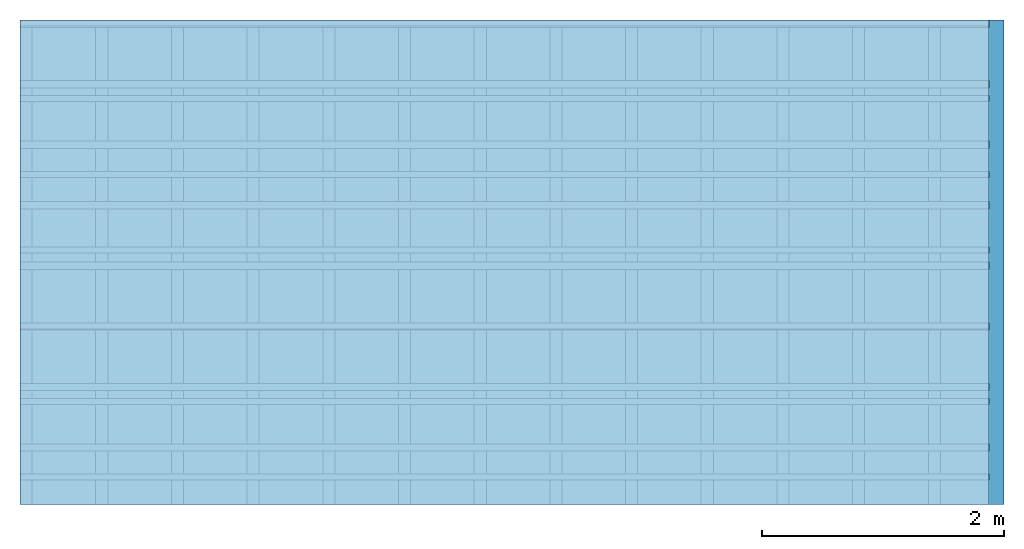
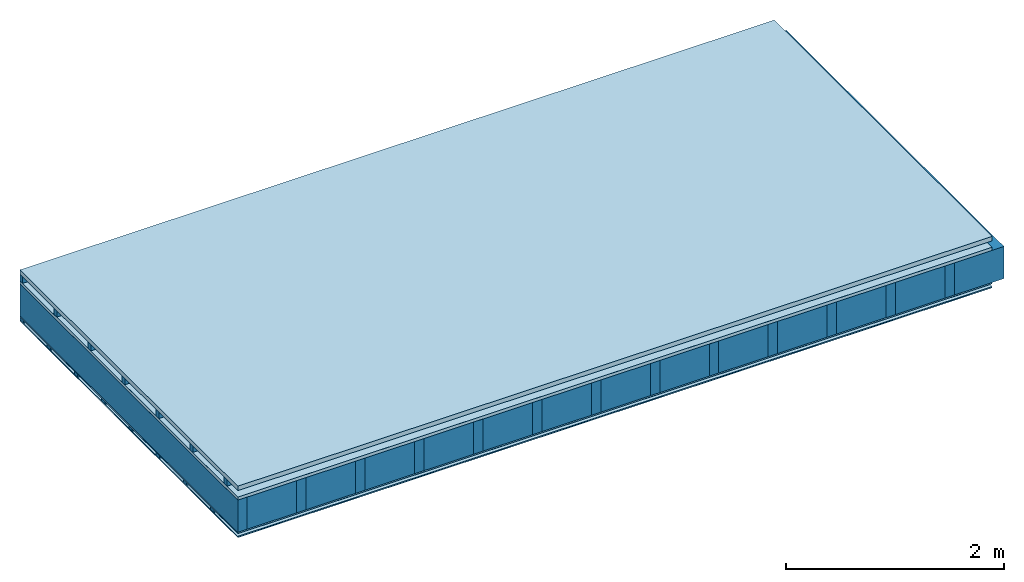
# One storey: 7 plates, 4 members, 1 element without a shape of its own.
"""IFC4 building model written with IfcOpenShell, lengths in metres."""

from ifc_helpers import new_model, si_unit, derived_unit, direction, frame, frame_2d, origin, origin_with_axes, place, context, project, spatial, rectangle, extrude, material, layer, layer_set, type_object, element, aggregate, save


model = new_model("IFC4")

# Units and contexts
plan_context = context("Plan", 3, precision=1e-05, world=origin(), true_north=direction((0.0, 1.0)))
model_context = context("Model", 3, precision=1e-05, world=origin(), true_north=direction((0.0, 1.0)))
ifc_project = project(units=[si_unit("LENGTHUNIT", "METRE"), derived_unit("SOUNDPRESSUREUNIT", [(si_unit("PRESSUREUNIT", "PASCAL", prefix="MICRO"), 0)]), si_unit("ENERGYUNIT", "JOULE", prefix="MEGA"), si_unit("MASSUNIT", "GRAM", prefix="KILO"), derived_unit("THERMALTRANSMITTANCEUNIT", [(si_unit("POWERUNIT", "WATT"), 1), (si_unit("AREAUNIT", "SQUARE_METRE"), -1), (si_unit("THERMODYNAMICTEMPERATUREUNIT", "KELVIN"), -1)]), derived_unit("AREADENSITYUNIT", [(si_unit("MASSUNIT", "GRAM", prefix="KILO"), 1), (si_unit("AREAUNIT", "SQUARE_METRE"), -1)]), derived_unit("USERDEFINED", [(si_unit("ENERGYUNIT", "JOULE", prefix="MEGA"), 1), (si_unit("AREAUNIT", "SQUARE_METRE"), -1)])], contexts=[plan_context, model_context])

# Site, building, storey
site = spatial("IfcSite", under=ifc_project)
building_placement = place(None, origin())
building = spatial("IfcBuilding", under=site, at=building_placement)
storey_placement = place(building_placement, origin())
storey = spatial("IfcBuildingStorey", under=building, at=storey_placement)

# Slab, members, plates
ifc_material_1 = material(Name="Roof tiles", Category="03.015")
ifc_layer_1 = layer(ifc_material_1, 0.05, Name="Roofing")
ifc_layer_2 = layer(None, 0.072, Name="Battens / profiles")
ifc_material_2 = material(Name="Roofing underlay", Category="09.008")
ifc_layer_3 = layer(ifc_material_2, 0.00018, Name="Under the roof")
ifc_material_3 = material(Category="10.009")
ifc_layer_4 = layer(ifc_material_3, 0.035, Name="Sub-floor")
ifc_material_4 = material(Name="of the art")
ifc_layer_5 = layer(ifc_material_4, 0.0, Name="Bond")
ifc_layer_6 = layer(None, 0.36, Name="Supporting structure")
ifc_material_5 = material(Name="OSB3 panel", Category="07.013")
ifc_layer_7 = layer(ifc_material_5, 0.015, Name="Lower layer 1")
ifc_material_6 = material(Name="Vapor barrier polyethylene (PE)", Category="09.002")
ifc_layer_8 = layer(ifc_material_6, 0.00025, Name="Vapor barrier")
ifc_layer_9 = layer(None, 0.03, Name="Battens / profiles")
ifc_material_7 = material(Name="Plasterboard type A", Category="03.008")
ifc_layer_10 = layer(ifc_material_7, 0.0125, Name="Covering below 1st layer")
ifc_material_8 = material(Category="04.001")
ifc_layer_11 = layer(ifc_material_8, 0.003, Name="Surface below")
ifc_layer_set = layer_set([ifc_layer_1, ifc_layer_2, ifc_layer_3, ifc_layer_4, ifc_layer_5, ifc_layer_6, ifc_layer_7, ifc_layer_8, ifc_layer_9, ifc_layer_10, ifc_layer_11])
slab_type = type_object("IfcSlabType", Name="E0180", PredefinedType="NOTDEFINED", material=ifc_layer_set)
slab_placement = place(None, frame((0.0, 0.0, 0.0), z_axis=(0.0, 0.0, -1.0), x_axis=(1.0, 0.0, 0.0)))
slab = element("IfcSlab", 1, at=slab_placement, inside=storey, type_object=slab_type, material=ifc_layer_set, Name="Slab #1")
ifc_material_9 = material()
member_1_placement = place(slab_placement, origin())
member_1 = element("IfcMember", 2, at=member_1_placement, material=ifc_material_9, Name="Battens / profiles", context=plan_context, shape_type="SweptSolid", body=[
    extrude(rectangle(XDim=0.05, YDim=0.072, at=frame_2d((0.025, 0.036), x_axis=(1.0, 0.0))), frame((0.0, 0.0, 0.05), z_axis=(1.0, 0.0, 0.0), x_axis=(0.0, 1.0, 0.0)), (0.0, 0.0, 1.0), 8.0),
    extrude(rectangle(XDim=0.05, YDim=0.072, at=frame_2d((0.025, 0.036), x_axis=(1.0, 0.0))), frame((0.0, 0.625, 0.05), z_axis=(1.0, 0.0, 0.0), x_axis=(0.0, 1.0, 0.0)), (0.0, 0.0, 1.0), 8.0),
    extrude(rectangle(XDim=0.05, YDim=0.072, at=frame_2d((0.025, 0.036), x_axis=(1.0, 0.0))), frame((0.0, 1.25, 0.05), z_axis=(1.0, 0.0, 0.0), x_axis=(0.0, 1.0, 0.0)), (0.0, 0.0, 1.0), 8.0),
    extrude(rectangle(XDim=0.05, YDim=0.072, at=frame_2d((0.025, 0.036), x_axis=(1.0, 0.0))), frame((0.0, 1.875, 0.05), z_axis=(1.0, 0.0, 0.0), x_axis=(0.0, 1.0, 0.0)), (0.0, 0.0, 1.0), 8.0),
    extrude(rectangle(XDim=0.05, YDim=0.072, at=frame_2d((0.025, 0.036), x_axis=(1.0, 0.0))), frame((0.0, 2.5, 0.05), z_axis=(1.0, 0.0, 0.0), x_axis=(0.0, 1.0, 0.0)), (0.0, 0.0, 1.0), 8.0),
    extrude(rectangle(XDim=0.05, YDim=0.072, at=frame_2d((0.025, 0.036), x_axis=(1.0, 0.0))), frame((0.0, 3.125, 0.05), z_axis=(1.0, 0.0, 0.0), x_axis=(0.0, 1.0, 0.0)), (0.0, 0.0, 1.0), 8.0),
    extrude(rectangle(XDim=0.05, YDim=0.072, at=frame_2d((0.025, 0.036), x_axis=(1.0, 0.0))), frame((0.0, 3.75, 0.05), z_axis=(1.0, 0.0, 0.0), x_axis=(0.0, 1.0, 0.0)), (0.0, 0.0, 1.0), 8.0),
])
ifc_material_10 = material()
member_2_placement = place(slab_placement, origin())
member_2 = element("IfcMember", 3, at=member_2_placement, material=ifc_material_10, Name="Supporting structure", context=plan_context, shape_type="SweptSolid", body=[
    extrude(rectangle(XDim=0.1, YDim=0.36, at=frame_2d((0.05, 0.18), x_axis=(1.0, 0.0))), frame((0.0, 4.0, 0.15718), z_axis=(0.0, -1.0, 0.0), x_axis=(1.0, 0.0, 0.0)), (0.0, 0.0, 1.0), 4.0),
    extrude(rectangle(XDim=0.1, YDim=0.36, at=frame_2d((0.05, 0.18), x_axis=(1.0, 0.0))), frame((0.625, 4.0, 0.15718), z_axis=(0.0, -1.0, 0.0), x_axis=(1.0, 0.0, 0.0)), (0.0, 0.0, 1.0), 4.0),
    extrude(rectangle(XDim=0.1, YDim=0.36, at=frame_2d((0.05, 0.18), x_axis=(1.0, 0.0))), frame((1.25, 4.0, 0.15718), z_axis=(0.0, -1.0, 0.0), x_axis=(1.0, 0.0, 0.0)), (0.0, 0.0, 1.0), 4.0),
    extrude(rectangle(XDim=0.1, YDim=0.36, at=frame_2d((0.05, 0.18), x_axis=(1.0, 0.0))), frame((1.875, 4.0, 0.15718), z_axis=(0.0, -1.0, 0.0), x_axis=(1.0, 0.0, 0.0)), (0.0, 0.0, 1.0), 4.0),
    extrude(rectangle(XDim=0.1, YDim=0.36, at=frame_2d((0.05, 0.18), x_axis=(1.0, 0.0))), frame((2.5, 4.0, 0.15718), z_axis=(0.0, -1.0, 0.0), x_axis=(1.0, 0.0, 0.0)), (0.0, 0.0, 1.0), 4.0),
    extrude(rectangle(XDim=0.1, YDim=0.36, at=frame_2d((0.05, 0.18), x_axis=(1.0, 0.0))), frame((3.125, 4.0, 0.15718), z_axis=(0.0, -1.0, 0.0), x_axis=(1.0, 0.0, 0.0)), (0.0, 0.0, 1.0), 4.0),
    extrude(rectangle(XDim=0.1, YDim=0.36, at=frame_2d((0.05, 0.18), x_axis=(1.0, 0.0))), frame((3.75, 4.0, 0.15718), z_axis=(0.0, -1.0, 0.0), x_axis=(1.0, 0.0, 0.0)), (0.0, 0.0, 1.0), 4.0),
    extrude(rectangle(XDim=0.1, YDim=0.36, at=frame_2d((0.05, 0.18), x_axis=(1.0, 0.0))), frame((4.375, 4.0, 0.15718), z_axis=(0.0, -1.0, 0.0), x_axis=(1.0, 0.0, 0.0)), (0.0, 0.0, 1.0), 4.0),
    extrude(rectangle(XDim=0.1, YDim=0.36, at=frame_2d((0.05, 0.18), x_axis=(1.0, 0.0))), frame((5.0, 4.0, 0.15718), z_axis=(0.0, -1.0, 0.0), x_axis=(1.0, 0.0, 0.0)), (0.0, 0.0, 1.0), 4.0),
    extrude(rectangle(XDim=0.1, YDim=0.36, at=frame_2d((0.05, 0.18), x_axis=(1.0, 0.0))), frame((5.625, 4.0, 0.15718), z_axis=(0.0, -1.0, 0.0), x_axis=(1.0, 0.0, 0.0)), (0.0, 0.0, 1.0), 4.0),
    extrude(rectangle(XDim=0.1, YDim=0.36, at=frame_2d((0.05, 0.18), x_axis=(1.0, 0.0))), frame((6.25, 4.0, 0.15718), z_axis=(0.0, -1.0, 0.0), x_axis=(1.0, 0.0, 0.0)), (0.0, 0.0, 1.0), 4.0),
    extrude(rectangle(XDim=0.1, YDim=0.36, at=frame_2d((0.05, 0.18), x_axis=(1.0, 0.0))), frame((6.875, 4.0, 0.15718), z_axis=(0.0, -1.0, 0.0), x_axis=(1.0, 0.0, 0.0)), (0.0, 0.0, 1.0), 4.0),
    extrude(rectangle(XDim=0.1, YDim=0.36, at=frame_2d((0.05, 0.18), x_axis=(1.0, 0.0))), frame((7.5, 4.0, 0.15718), z_axis=(0.0, -1.0, 0.0), x_axis=(1.0, 0.0, 0.0)), (0.0, 0.0, 1.0), 4.0),
])
ifc_material_11 = material()
member_3_placement = place(slab_placement, origin())
member_3 = element("IfcMember", 4, at=member_3_placement, material=ifc_material_11, Name="Cavity", context=plan_context, shape_type="SweptSolid", body=[
    extrude(rectangle(XDim=0.525, YDim=0.36, at=frame_2d((0.2625, 0.18), x_axis=(1.0, 0.0))), frame((0.1, 4.0, 0.15718), z_axis=(0.0, -1.0, 0.0), x_axis=(1.0, 0.0, 0.0)), (0.0, 0.0, 1.0), 4.0),
    extrude(rectangle(XDim=0.525, YDim=0.36, at=frame_2d((0.2625, 0.18), x_axis=(1.0, 0.0))), frame((0.725, 4.0, 0.15718), z_axis=(0.0, -1.0, 0.0), x_axis=(1.0, 0.0, 0.0)), (0.0, 0.0, 1.0), 4.0),
    extrude(rectangle(XDim=0.525, YDim=0.36, at=frame_2d((0.2625, 0.18), x_axis=(1.0, 0.0))), frame((1.35, 4.0, 0.15718), z_axis=(0.0, -1.0, 0.0), x_axis=(1.0, 0.0, 0.0)), (0.0, 0.0, 1.0), 4.0),
    extrude(rectangle(XDim=0.525, YDim=0.36, at=frame_2d((0.2625, 0.18), x_axis=(1.0, 0.0))), frame((1.975, 4.0, 0.15718), z_axis=(0.0, -1.0, 0.0), x_axis=(1.0, 0.0, 0.0)), (0.0, 0.0, 1.0), 4.0),
    extrude(rectangle(XDim=0.525, YDim=0.36, at=frame_2d((0.2625, 0.18), x_axis=(1.0, 0.0))), frame((2.6, 4.0, 0.15718), z_axis=(0.0, -1.0, 0.0), x_axis=(1.0, 0.0, 0.0)), (0.0, 0.0, 1.0), 4.0),
    extrude(rectangle(XDim=0.525, YDim=0.36, at=frame_2d((0.2625, 0.18), x_axis=(1.0, 0.0))), frame((3.225, 4.0, 0.15718), z_axis=(0.0, -1.0, 0.0), x_axis=(1.0, 0.0, 0.0)), (0.0, 0.0, 1.0), 4.0),
    extrude(rectangle(XDim=0.525, YDim=0.36, at=frame_2d((0.2625, 0.18), x_axis=(1.0, 0.0))), frame((3.85, 4.0, 0.15718), z_axis=(0.0, -1.0, 0.0), x_axis=(1.0, 0.0, 0.0)), (0.0, 0.0, 1.0), 4.0),
    extrude(rectangle(XDim=0.525, YDim=0.36, at=frame_2d((0.2625, 0.18), x_axis=(1.0, 0.0))), frame((4.475, 4.0, 0.15718), z_axis=(0.0, -1.0, 0.0), x_axis=(1.0, 0.0, 0.0)), (0.0, 0.0, 1.0), 4.0),
    extrude(rectangle(XDim=0.525, YDim=0.36, at=frame_2d((0.2625, 0.18), x_axis=(1.0, 0.0))), frame((5.1, 4.0, 0.15718), z_axis=(0.0, -1.0, 0.0), x_axis=(1.0, 0.0, 0.0)), (0.0, 0.0, 1.0), 4.0),
    extrude(rectangle(XDim=0.525, YDim=0.36, at=frame_2d((0.2625, 0.18), x_axis=(1.0, 0.0))), frame((5.725, 4.0, 0.15718), z_axis=(0.0, -1.0, 0.0), x_axis=(1.0, 0.0, 0.0)), (0.0, 0.0, 1.0), 4.0),
    extrude(rectangle(XDim=0.525, YDim=0.36, at=frame_2d((0.2625, 0.18), x_axis=(1.0, 0.0))), frame((6.35, 4.0, 0.15718), z_axis=(0.0, -1.0, 0.0), x_axis=(1.0, 0.0, 0.0)), (0.0, 0.0, 1.0), 4.0),
    extrude(rectangle(XDim=0.525, YDim=0.36, at=frame_2d((0.2625, 0.18), x_axis=(1.0, 0.0))), frame((6.975, 4.0, 0.15718), z_axis=(0.0, -1.0, 0.0), x_axis=(1.0, 0.0, 0.0)), (0.0, 0.0, 1.0), 4.0),
    extrude(rectangle(XDim=0.525, YDim=0.36, at=frame_2d((0.2625, 0.18), x_axis=(1.0, 0.0))), frame((7.6, 4.0, 0.15718), z_axis=(0.0, -1.0, 0.0), x_axis=(1.0, 0.0, 0.0)), (0.0, 0.0, 1.0), 4.0),
])
ifc_material_12 = material()
member_4_placement = place(slab_placement, origin())
member_4 = element("IfcMember", 5, at=member_4_placement, material=ifc_material_12, Name="Battens / profiles", context=plan_context, shape_type="SweptSolid", body=[
    extrude(rectangle(XDim=0.06, YDim=0.03, at=frame_2d((0.03, 0.015), x_axis=(1.0, 0.0))), frame((0.0, 0.0, 0.53243), z_axis=(1.0, 0.0, 0.0), x_axis=(0.0, 1.0, 0.0)), (0.0, 0.0, 1.0), 8.0),
    extrude(rectangle(XDim=0.06, YDim=0.03, at=frame_2d((0.03, 0.015), x_axis=(1.0, 0.0))), frame((0.0, 0.5, 0.53243), z_axis=(1.0, 0.0, 0.0), x_axis=(0.0, 1.0, 0.0)), (0.0, 0.0, 1.0), 8.0),
    extrude(rectangle(XDim=0.06, YDim=0.03, at=frame_2d((0.03, 0.015), x_axis=(1.0, 0.0))), frame((0.0, 1.0, 0.53243), z_axis=(1.0, 0.0, 0.0), x_axis=(0.0, 1.0, 0.0)), (0.0, 0.0, 1.0), 8.0),
    extrude(rectangle(XDim=0.06, YDim=0.03, at=frame_2d((0.03, 0.015), x_axis=(1.0, 0.0))), frame((0.0, 1.5, 0.53243), z_axis=(1.0, 0.0, 0.0), x_axis=(0.0, 1.0, 0.0)), (0.0, 0.0, 1.0), 8.0),
    extrude(rectangle(XDim=0.06, YDim=0.03, at=frame_2d((0.03, 0.015), x_axis=(1.0, 0.0))), frame((0.0, 2.0, 0.53243), z_axis=(1.0, 0.0, 0.0), x_axis=(0.0, 1.0, 0.0)), (0.0, 0.0, 1.0), 8.0),
    extrude(rectangle(XDim=0.06, YDim=0.03, at=frame_2d((0.03, 0.015), x_axis=(1.0, 0.0))), frame((0.0, 2.5, 0.53243), z_axis=(1.0, 0.0, 0.0), x_axis=(0.0, 1.0, 0.0)), (0.0, 0.0, 1.0), 8.0),
    extrude(rectangle(XDim=0.06, YDim=0.03, at=frame_2d((0.03, 0.015), x_axis=(1.0, 0.0))), frame((0.0, 3.0, 0.53243), z_axis=(1.0, 0.0, 0.0), x_axis=(0.0, 1.0, 0.0)), (0.0, 0.0, 1.0), 8.0),
    extrude(rectangle(XDim=0.06, YDim=0.03, at=frame_2d((0.03, 0.015), x_axis=(1.0, 0.0))), frame((0.0, 3.5, 0.53243), z_axis=(1.0, 0.0, 0.0), x_axis=(0.0, 1.0, 0.0)), (0.0, 0.0, 1.0), 8.0),
])
plate_1_placement = place(slab_placement, origin())
plate_1 = element("IfcPlate", 6, at=plate_1_placement, material=ifc_material_1, Name="Roofing", context=plan_context, shape_type="SweptSolid", body=[
    extrude(rectangle(XDim=8.0, YDim=4.0, at=frame_2d((4.0, 2.0), x_axis=(1.0, 0.0))), origin_with_axes(), (0.0, 0.0, 1.0), 0.05),
])
plate_2_placement = place(slab_placement, origin())
plate_2 = element("IfcPlate", 7, at=plate_2_placement, material=ifc_material_2, Name="Under the roof", context=plan_context, shape_type="SweptSolid", body=[
    extrude(rectangle(XDim=8.0, YDim=4.0, at=frame_2d((4.0, 2.0), x_axis=(1.0, 0.0))), frame((0.0, 0.0, 0.122), z_axis=(0.0, 0.0, 1.0), x_axis=(1.0, 0.0, 0.0)), (0.0, 0.0, 1.0), 0.00018),
])
plate_3_placement = place(slab_placement, origin())
plate_3 = element("IfcPlate", 8, at=plate_3_placement, material=ifc_material_3, Name="Sub-floor", context=plan_context, shape_type="SweptSolid", body=[
    extrude(rectangle(XDim=8.0, YDim=4.0, at=frame_2d((4.0, 2.0), x_axis=(1.0, 0.0))), frame((0.0, 0.0, 0.12218), z_axis=(0.0, 0.0, 1.0), x_axis=(1.0, 0.0, 0.0)), (0.0, 0.0, 1.0), 0.035),
])
plate_4_placement = place(slab_placement, origin())
plate_4 = element("IfcPlate", 9, at=plate_4_placement, material=ifc_material_5, Name="Lower layer 1", context=plan_context, shape_type="SweptSolid", body=[
    extrude(rectangle(XDim=8.0, YDim=4.0, at=frame_2d((4.0, 2.0), x_axis=(1.0, 0.0))), frame((0.0, 0.0, 0.51718), z_axis=(0.0, 0.0, 1.0), x_axis=(1.0, 0.0, 0.0)), (0.0, 0.0, 1.0), 0.015),
])
plate_5_placement = place(slab_placement, origin())
plate_5 = element("IfcPlate", 10, at=plate_5_placement, material=ifc_material_6, Name="Vapor barrier", context=plan_context, shape_type="SweptSolid", body=[
    extrude(rectangle(XDim=8.0, YDim=4.0, at=frame_2d((4.0, 2.0), x_axis=(1.0, 0.0))), frame((0.0, 0.0, 0.53218), z_axis=(0.0, 0.0, 1.0), x_axis=(1.0, 0.0, 0.0)), (0.0, 0.0, 1.0), 0.00025),
])
plate_6_placement = place(slab_placement, origin())
plate_6 = element("IfcPlate", 11, at=plate_6_placement, material=ifc_material_7, Name="Covering below 1st layer", context=plan_context, shape_type="SweptSolid", body=[
    extrude(rectangle(XDim=8.0, YDim=4.0, at=frame_2d((4.0, 2.0), x_axis=(1.0, 0.0))), frame((0.0, 0.0, 0.56243), z_axis=(0.0, 0.0, 1.0), x_axis=(1.0, 0.0, 0.0)), (0.0, 0.0, 1.0), 0.0125),
])
plate_7_placement = place(slab_placement, origin())
plate_7 = element("IfcPlate", 12, at=plate_7_placement, material=ifc_material_8, Name="Surface below", context=plan_context, shape_type="SweptSolid", body=[
    extrude(rectangle(XDim=8.0, YDim=4.0, at=frame_2d((4.0, 2.0), x_axis=(1.0, 0.0))), frame((0.0, 0.0, 0.57493), z_axis=(0.0, 0.0, 1.0), x_axis=(1.0, 0.0, 0.0)), (0.0, 0.0, 1.0), 0.003),
])
aggregate(slab, [plate_1, member_1, plate_2, plate_3, member_2, member_3, plate_4, plate_5, member_4, plate_6, plate_7])

save(model, "model.ifc")
